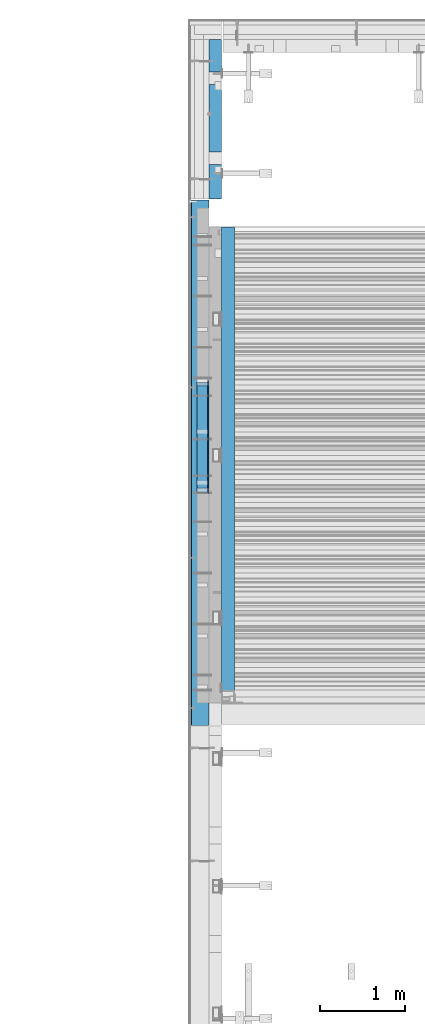
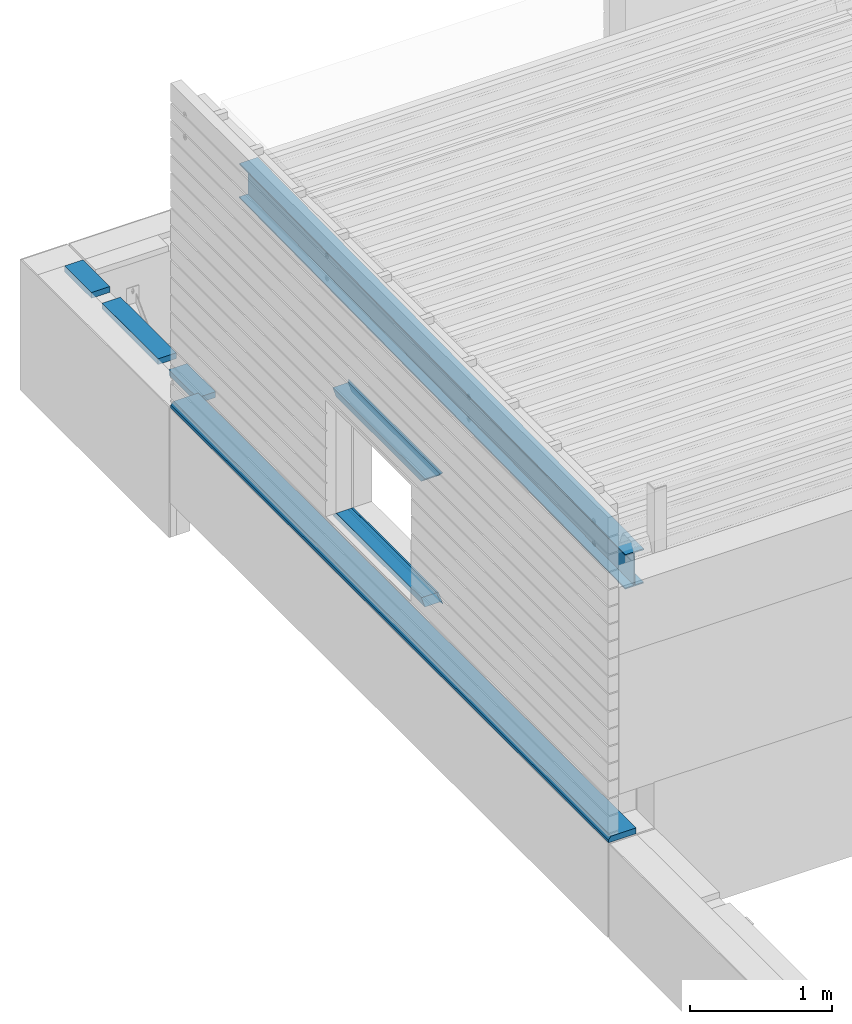
# One storey, part 24 of 153: 9 beams, 3 elements without a shape of their own.
"""IFC2X3 building model written with IfcOpenShell, lengths in millimetres."""

from ifc_helpers import new_model, si_unit, frame, origin_with_axes, place, context, subcontext, project, spatial, faceted_brep, material, type_object, element, aggregate, save


model = new_model("IFC2X3")

# Units and contexts
model_context = context("Model", 3, precision=1e-05, world=origin_with_axes())
body_context = subcontext(model_context, "Body", "Model", "MODEL_VIEW")
ifc_project = project(units=[si_unit("LENGTHUNIT", "METRE", prefix="MILLI"), si_unit("AREAUNIT", "SQUARE_METRE"), si_unit("VOLUMEUNIT", "CUBIC_METRE"), si_unit("MASSUNIT", "GRAM", prefix="KILO"), si_unit("TIMEUNIT", "SECOND"), si_unit("PLANEANGLEUNIT", "RADIAN"), si_unit("SOLIDANGLEUNIT", "STERADIAN"), si_unit("THERMODYNAMICTEMPERATUREUNIT", "DEGREE_CELSIUS"), si_unit("LUMINOUSINTENSITYUNIT", "LUMEN")], contexts=[model_context])

# Site, building, storey
site_placement = place(None, origin_with_axes())
site = spatial("IfcSite", under=ifc_project, at=site_placement, CompositionType="ELEMENT")
building_placement = place(site_placement, origin_with_axes())
building = spatial("IfcBuilding", under=site, at=building_placement, CompositionType="ELEMENT")
storey_placement = place(building_placement, origin_with_axes())
storey = spatial("IfcBuildingStorey", under=building, at=storey_placement, Name="8", CompositionType="ELEMENT", Elevation=0.0)

# Assembly, beams
assembly_1_placement = place(storey_placement, origin_with_axes())
assembly_1 = element("IfcElementAssembly", 1, at=assembly_1_placement, inside=storey, AssemblyPlace="NOTDEFINED", PredefinedType="REINFORCEMENT_UNIT")
ifc_material_1 = material(Name="CONCRETE/C25/30")
beam_type_1 = type_object("IfcBeamType", PredefinedType="NOTDEFINED")
beam_1_placement = place(assembly_1_placement, frame((7842.5, 18766.2493324854, 105017.5), z_axis=(0.0, 0.0, -1.0), x_axis=(0.0, -1.0, 0.0)))
beam_1 = element("IfcBeam", 2, at=beam_1_placement, type_object=beam_type_1, material=ifc_material_1, context=body_context, shape_type="Brep", body=[
    faceted_brep([(15.0000000000036, 7.5, 7.5), (0.0, -7.5, -7.5), (15.0000000000036, -7.5, 7.5), (1314.99933248539, -7.5, 7.5), (1314.99933248539, 7.5, 7.5), (1329.99933248539, -7.5, -7.5)], [[[0, 1, 2]], [[0, 2, 3, 4]], [[1, 0, 4, 5]], [[2, 1, 5, 3]], [[4, 3, 5]]]),
])
beam_2_placement = place(assembly_1_placement, frame((7842.5, 17436.25, 103902.5), z_axis=(0.0, 0.0, 1.0), x_axis=(0.0, 1.0, 0.0)))
beam_2 = element("IfcBeam", 3, at=beam_2_placement, type_object=beam_type_1, material=ifc_material_1, context=body_context, shape_type="Brep", body=[
    faceted_brep([(1314.99933248539, 7.5, 7.5), (1314.99933248539, -7.5, 7.5), (1329.99933248539, -7.5, -7.5), (15.0000000000036, -7.5, 7.5), (0.0, -7.5, -7.5), (15.0000000000036, 7.5, 7.5)], [[[0, 1, 2]], [[3, 4, 2, 1]], [[4, 5, 0, 2]], [[5, 3, 1, 0]], [[5, 4, 3]]]),
])
beam_type_2 = type_object("IfcBeamType", PredefinedType="NOTDEFINED")
beam_3_placement = place(assembly_1_placement, frame((7842.5, 18751.2493324854, 104985.0), z_axis=(0.0, 0.0, -1.0), x_axis=(0.0, -1.0, 0.0)))
beam_3 = element("IfcBeam", 4, at=beam_3_placement, type_object=beam_type_2, material=ifc_material_1, context=body_context, shape_type="Brep", body=[
    faceted_brep([(50.0000000000036, 7.5, 25.0), (0.0, 7.5, -25.0), (0.0, -7.5, -25.0), (49.9993324853858, -7.5, 25.0), (1249.99933248539, -7.5, 25.0), (1249.99933248538, 7.5, 25.0), (1299.99933248539, 7.5, -25.0), (1299.99933248539, -7.5, -25.0)], [[[0, 1, 2, 3]], [[0, 3, 4, 5]], [[1, 0, 5, 6]], [[2, 1, 6, 7]], [[3, 2, 7, 4]], [[6, 5, 4, 7]]]),
])
beam_4_placement = place(assembly_1_placement, frame((7842.5, 17451.25, 103935.0), z_axis=(0.0, 0.0, 1.0), x_axis=(0.0, 1.0, 0.0)))
beam_4 = element("IfcBeam", 5, at=beam_4_placement, type_object=beam_type_2, material=ifc_material_1, context=body_context, shape_type="Brep", body=[
    faceted_brep([(1249.99933248538, 7.5, 25.0), (1250.0, -7.5, 25.0), (1299.99933248539, -7.5, -25.0), (1299.99933248539, 7.5, -25.0), (50.0, -7.5, 25.0), (0.0, -7.5, -25.0), (0.0, 7.5, -25.0), (50.0000000000036, 7.5, 25.0)], [[[0, 1, 2, 3]], [[2, 1, 4, 5]], [[5, 6, 3, 2]], [[6, 7, 0, 3]], [[1, 0, 7, 4]], [[7, 6, 5, 4]]]),
])
ifc_material_2 = material(Name="TIMBER")
beam_type_3 = type_object("IfcBeamType", Name="50X125", PredefinedType="NOTDEFINED")
beam_5_placement = place(assembly_1_placement, frame((7772.5, 18751.2493324854, 104985.0), z_axis=(0.0, 0.0, -1.0), x_axis=(0.0, -1.0, 0.0)))
beam_5 = element("IfcBeam", 6, at=beam_5_placement, type_object=beam_type_3, material=ifc_material_2, ObjectType="50X125", context=body_context, shape_type="Brep", body=[
    faceted_brep([(49.9999999999818, 62.5, 25.0), (0.0, 62.5, -25.0), (0.0, -62.5, -25.0), (49.9999999999818, -62.5, 25.0), (1249.99933248538, -62.5, 25.0), (1249.99933248538, 62.5, 25.0), (1299.99933248539, 62.5, -25.0), (1299.99933248539, -62.5, -25.0)], [[[0, 1, 2, 3]], [[0, 3, 4, 5]], [[1, 0, 5, 6]], [[2, 1, 6, 7]], [[3, 2, 7, 4]], [[6, 5, 4, 7]]]),
])
beam_6_placement = place(assembly_1_placement, frame((7772.5, 17451.25, 103935.0), z_axis=(0.0, 0.0, 1.0), x_axis=(0.0, 1.0, 0.0)))
beam_6 = element("IfcBeam", 7, at=beam_6_placement, type_object=beam_type_3, material=ifc_material_2, ObjectType="50X125", context=body_context, shape_type="Brep", body=[
    faceted_brep([(1299.99933248539, 62.5, -25.0), (1249.99933248538, 62.5, 25.0), (1249.99933248538, -62.5, 25.0), (1299.99933248539, -62.5, -25.0), (49.9999999999818, -62.5, 25.0), (0.0, -62.5, -25.0), (0.0, 62.5, -25.0), (49.9999999999818, 62.5, 25.0)], [[[0, 1, 2, 3]], [[4, 5, 3, 2]], [[5, 6, 0, 3]], [[6, 7, 1, 0]], [[7, 4, 2, 1]], [[7, 6, 5, 4]]]),
])

# Assembly, beam
assembly_2_placement = place(storey_placement, origin_with_axes())
assembly_2 = element("IfcElementAssembly", 8, at=assembly_2_placement, inside=storey, AssemblyPlace="NOTDEFINED", PredefinedType="REINFORCEMENT_UNIT")
beam_type_4 = type_object("IfcBeamType", PredefinedType="NOTDEFINED")
beam_7_placement = place(assembly_2_placement, frame((7925.00000000001, 20899.9999481269, 103545.0), z_axis=(0.0, 0.0, 1.0), x_axis=(0.0, 1.0, 0.0)))
beam_7 = element("IfcBeam", 9, at=beam_7_placement, type_object=beam_type_4, material=ifc_material_2, context=body_context, shape_type="Brep", body=[
    faceted_brep([(0.0, -75.0, -25.0), (1.81898940354586e-12, -75.0000000000009, 25.0), (1.81898940354586e-12, 75.0, 25.0), (0.0, 75.0, -25.0), (401.999928838522, 75.0, -25.0), (401.999887467478, -74.9999999999991, -25.0), (401.999887467478, -74.9999062870029, 25.0), (401.999928838522, 75.0, 25.0), (1491.99988746732, -75.000494216757, 25.0), (1491.99993771732, 74.9999999999991, 25.0), (1491.99993771732, 74.9999999999991, -25.0), (1491.99988746731, -75.0, -25.0), (1870.0020093227, -75.0, 25.0), (1870.0020093227, -75.0, -25.0), (1870.0020093227, 75.0000000000009, -25.0), (1870.0020093227, 75.0000000000009, 25.0), (1341.99988746733, -75.0004439670029, 25.0), (1341.99988746733, -75.0, -25.0), (1341.99992883837, 75.0, -25.0), (1341.99992883837, 75.0, 25.0), (551.999887467471, -74.9999565367571, 25.0), (551.999937717468, 74.9999999999991, 25.0), (551.999937717468, 74.9999999999991, -25.0), (551.999887467471, -74.9999999999991, -25.0)], [[[0, 1, 2, 3]], [[0, 3, 4, 5]], [[1, 0, 5, 6]], [[2, 1, 6, 7]], [[3, 2, 7, 4]], [[6, 5, 4, 7]], [[8, 9, 10, 11]], [[12, 13, 14, 15]], [[13, 12, 8, 11]], [[14, 13, 11, 10]], [[15, 14, 10, 9]], [[12, 15, 9, 8]], [[16, 17, 18, 19]], [[20, 21, 22, 23]], [[21, 20, 16, 19]], [[22, 21, 19, 18]], [[23, 22, 18, 17]], [[20, 23, 17, 16]]]),
])
aggregate(assembly_2, [beam_7])

# Beam
beam_type_5 = type_object("IfcBeamType", PredefinedType="NOTDEFINED")
beam_8_placement = place(assembly_1_placement, frame((7737.5, 20885.0, 103595.0), z_axis=(0.0, 0.0, -1.0), x_axis=(0.0, -1.0, 0.0)))
beam_8 = element("IfcBeam", 10, at=beam_8_placement, type_object=beam_type_5, material=ifc_material_2, context=body_context, shape_type="Brep", body=[
    faceted_brep([(0.0, 90.7545185089093, -25.0000000000146), (0.0, 112.5, -1.45519152283669e-11), (6167.97, 112.5, -1.45519152283669e-11), (6167.97, 90.7545185089093, -25.0), (0.0, 112.5, 25.0), (0.0, -112.5, 25.0), (6167.97, -112.5, 25.0), (6167.97, 112.5, 25.0), (0.0, -112.5, -25.0), (6167.97, -112.5, -25.0)], [[[0, 1, 2, 3]], [[4, 5, 6, 7]], [[5, 8, 9, 6]], [[9, 8, 0, 3]], [[7, 6, 9, 3, 2]], [[4, 7, 2, 1]], [[8, 5, 4, 1, 0]]]),
])

aggregate(assembly_1, [beam_1, beam_3, beam_2, beam_4, beam_5, beam_6, beam_8])

# Assembly, beam
assembly_3_placement = place(storey_placement, origin_with_axes())
assembly_3 = element("IfcElementAssembly", 11, at=assembly_3_placement, inside=storey, Name="Steel Assembly", AssemblyPlace="NOTDEFINED", PredefinedType="RIGID_FRAME")
ifc_material_3 = material(Name="STEEL/S355J2")
beam_type_6 = type_object("IfcBeamType", Name="IPE300", PredefinedType="NOTDEFINED")
beam_9_placement = place(assembly_3_placement, frame((8075.0, 15128.0908589853, 105518.668698035), z_axis=(0.0, -0.0124990270013869, 0.999921884110963), x_axis=(0.0, 0.999921884110963, 0.0124990270013883)))
beam_9 = element("IfcBeam", 12, at=beam_9_placement, type_object=beam_type_6, material=ifc_material_3, ObjectType="IPE300", context=body_context, shape_type="Brep", body=[
    faceted_brep([(3.63797880709171e-12, 75.0, -149.999999999985), (0.0, 75.0, -139.300000189993), (5440.87494889885, 75.0, -139.300000189993), (5440.87494889886, 75.0, -150.0), (0.0, 3.5499999525, -139.300000189993), (5440.87494889885, 3.5499999525, -139.300000189993), (0.0, 3.5499999525, 139.300000190022), (5440.87494889885, 3.5499999525, 139.300000190022), (0.0, 75.0, 139.300000190022), (5440.87494889885, 75.0, 139.300000190022), (3.63797880709171e-12, 75.0, 150.0), (5440.87494889885, 75.0, 150.0), (3.63797880709171e-12, -75.0, 150.0), (5440.87494889885, -75.0, 150.0), (0.0, -75.0, 139.300000190022), (5440.87494889885, -75.0, 139.300000190022), (0.0, -3.5499999525, 139.300000190022), (5440.87494889885, -3.5499999525, 139.300000190022), (0.0, -3.5499999525, -139.300000189993), (5440.87494889885, -3.5499999525, -139.300000189993), (0.0, -75.0, -139.300000189993), (5440.87494889885, -75.0, -139.300000189993), (3.63797880709171e-12, -75.0, -149.999999999985), (5440.87494889886, -75.0, -150.0)], [[[0, 1, 2, 3]], [[1, 4, 5, 2]], [[4, 6, 7, 5]], [[6, 8, 9, 7]], [[8, 10, 11, 9]], [[10, 12, 13, 11]], [[12, 14, 15, 13]], [[14, 16, 17, 15]], [[16, 18, 19, 17]], [[18, 20, 21, 19]], [[20, 22, 23, 21]], [[22, 0, 3, 23]], [[5, 7, 9, 11, 13, 15, 17, 19, 21, 23, 3, 2]], [[22, 20, 18, 16, 14, 12, 10, 8, 6, 4, 1, 0]]]),
])
aggregate(assembly_3, [beam_9])

save(model, "model.ifc")
